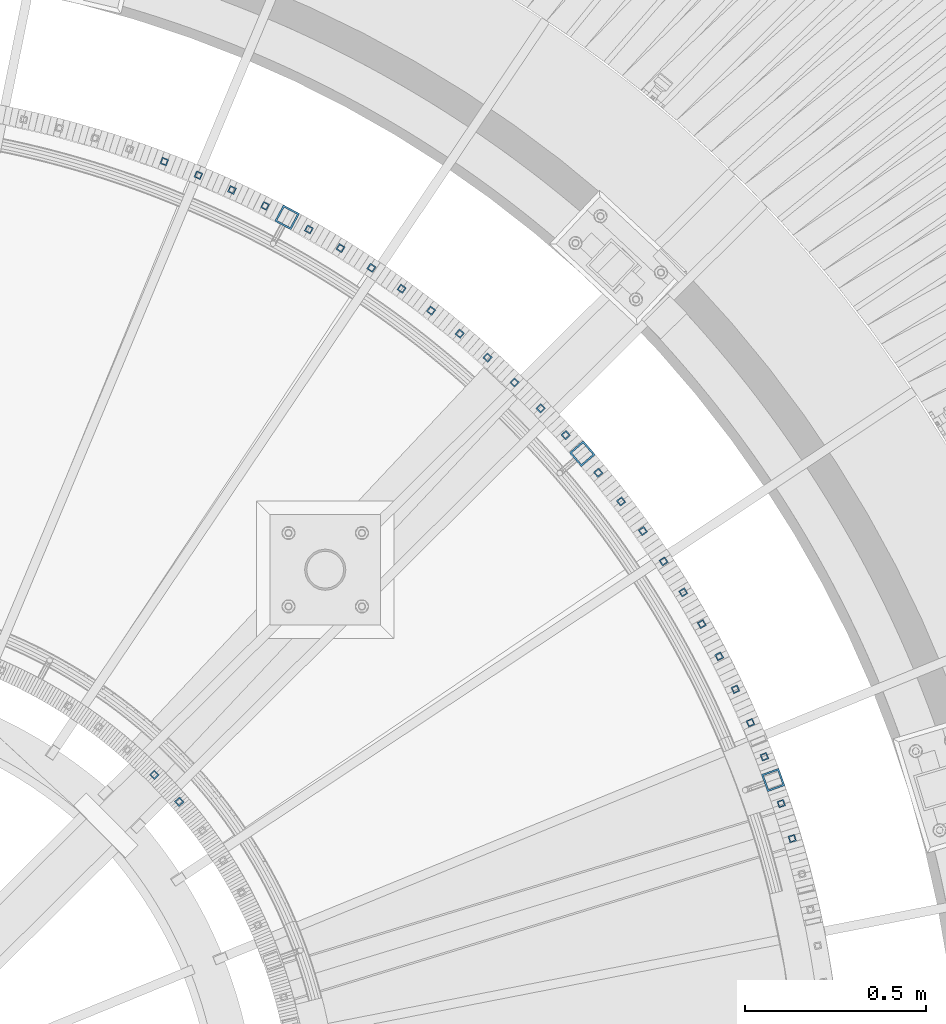
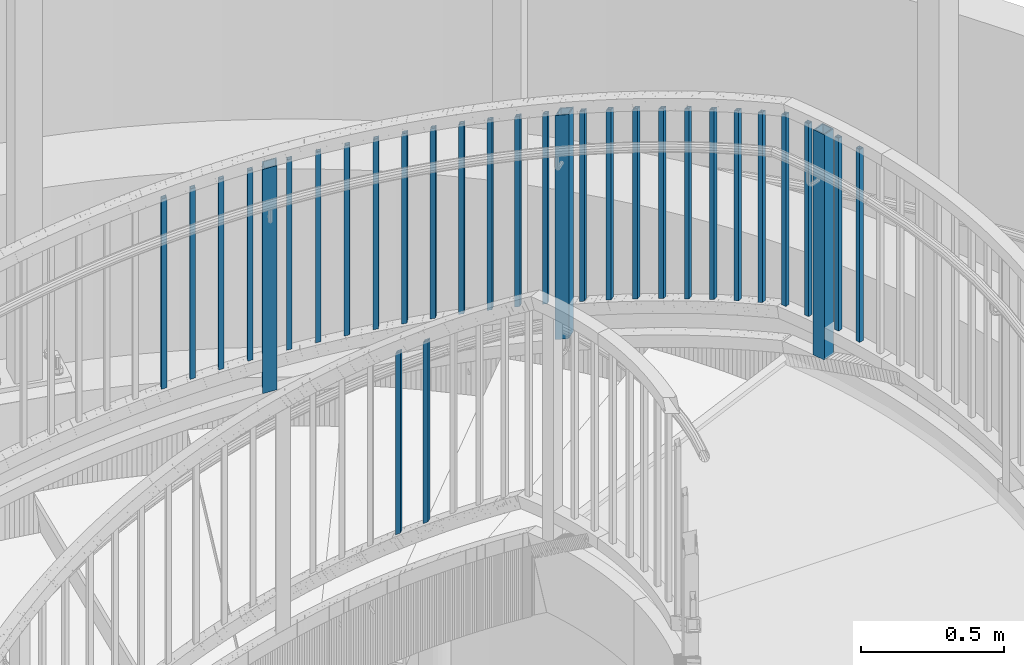
# One storey, part 267 of 975: 31 columns.
"""IFC2X3 building model written with IfcOpenShell, lengths in millimetres."""

import ifcopenshell
import ifcopenshell.guid

model = None  # the IFC model being written
_history = None  # IfcOwnerHistory: only IFC2X3 demands one
_inside = {}  # id of a spatial element -> (the spatial element, [elements in it])
_under = {}  # id of a project, library or spatial element -> (it, [spatial elements below it])
_declared = {}  # id of a project -> (the project, [libraries it declares])
_typed = {}  # id of a type object -> (the type object, [elements of that type])
_made_of = {}  # id of a material, layer set ... -> (it, [elements and type objects made of it])


def new_model(schema):
    """Start an empty IFC model of exactly this schema.

    Asked for "IFC4X3", IfcOpenShell would pick the latest addendum, in which some entities
    have other attributes; the version numbers below select the first issue.
    IFC2X3 requires an IfcOwnerHistory on every rooted entity: one is made here for all.
    """
    global model, _history
    if schema == "IFC4X3":
        model = ifcopenshell.file(schema_version=(4, 3, 0, 0))
    else:
        model = ifcopenshell.file(schema=schema)
    _inside.clear()
    _under.clear()
    _declared.clear()
    _typed.clear()
    _made_of.clear()
    _history = None
    if model.schema == "IFC2X3":
        org = make("IfcOrganization", Name="unknown")
        user = make(
            "IfcPersonAndOrganization",
            ThePerson=make("IfcPerson", FamilyName="unknown"),
            TheOrganization=org,
        )
        app = make(
            "IfcApplication",
            ApplicationDeveloper=org,
            Version="unknown",
            ApplicationFullName="unknown",
            ApplicationIdentifier="unknown",
        )
        _history = make(
            "IfcOwnerHistory",
            OwningUser=user,
            OwningApplication=app,
            ChangeAction="ADDED",
            CreationDate=0,
        )
    return model


def make(cls, **values):
    """One entity of the class cls with the attributes given. An attribute that is None is left unset."""
    return model.create_entity(
        cls, **{name: value for name, value in values.items() if value is not None}
    )


def rooted(cls, **values):
    """An entity with a GlobalId (a new one), such as an element, a storey or a relation."""
    return make(cls, GlobalId=ifcopenshell.guid.new(), OwnerHistory=_history, **values)


def si_unit(unit_type, name, prefix=None):
    """IfcSIUnit, for example si_unit("LENGTHUNIT", "METRE", prefix="MILLI")."""
    return make("IfcSIUnit", UnitType=unit_type, Prefix=prefix, Name=name)


def assignment(units):
    """IfcUnitAssignment: the units of a project."""
    return None if units is None else make("IfcUnitAssignment", Units=units)


def point(xyz):
    """IfcCartesianPoint."""
    return None if xyz is None else make("IfcCartesianPoint", Coordinates=xyz)


def direction(xyz):
    """IfcDirection."""
    return None if xyz is None else make("IfcDirection", DirectionRatios=xyz)


def frame(location, z_axis=None, x_axis=None):
    """IfcAxis2Placement3D, a coordinate frame: its origin and axes. An axis left out is left unset."""
    return make(
        "IfcAxis2Placement3D",
        Location=point(location),
        Axis=direction(z_axis),
        RefDirection=direction(x_axis),
    )


def origin_with_axes():
    """The frame at (0, 0, 0) with the z axis (0, 0, 1) and the x axis (1, 0, 0) written out."""
    return frame((0.0, 0.0, 0.0), z_axis=(0.0, 0.0, 1.0), x_axis=(1.0, 0.0, 0.0))


def place(relative_to, where):
    """IfcLocalPlacement: puts the frame where relative to a parent placement (None: the world)."""
    return make(
        "IfcLocalPlacement", PlacementRelTo=relative_to, RelativePlacement=where
    )


def context(
    kind, dimensions, precision=None, world=None, true_north=None, identifier=None
):
    """IfcGeometricRepresentationContext, for example the 3D "Model" context."""
    return make(
        "IfcGeometricRepresentationContext",
        ContextIdentifier=identifier,
        ContextType=kind,
        CoordinateSpaceDimension=dimensions,
        Precision=precision,
        WorldCoordinateSystem=world,
        TrueNorth=true_north,
    )


def subcontext(parent, identifier, kind, view, scale=None):
    """IfcGeometricRepresentationSubContext, for example "Body" below "Model"."""
    return make(
        "IfcGeometricRepresentationSubContext",
        ContextIdentifier=identifier,
        ContextType=kind,
        ParentContext=parent,
        TargetScale=scale,
        TargetView=view,
    )


def project(units=None, contexts=None):
    """IfcProject with its units and contexts."""
    return rooted(
        "IfcProject",
        Name="project",
        RepresentationContexts=contexts,
        UnitsInContext=assignment(units),
    )


def spatial(cls, under=None, at=None, **own):
    """A site, building, storey or space (cls), placed at a placement, below another one or the project."""
    s = rooted(cls, ObjectPlacement=at, **own)
    if under is not None:
        _under.setdefault(under.id(), (under, []))[1].append(s)
    return s


def faces_of(points, faces, orient=None, outer=None):
    """IfcFace entities. A face is a list of loops; a loop is a list of indices into points, from 0.

    orient and outer hold one flag for each loop. By default every Orientation is true, the
    first loop of a face is its IfcFaceOuterBound and the others are IfcFaceBound.
    """
    made = []
    for i, loops in enumerate(faces):
        bounds = []
        for j, loop in enumerate(loops):
            is_outer = j == 0 if outer is None else outer[i][j]
            bounds.append(
                make(
                    "IfcFaceOuterBound" if is_outer else "IfcFaceBound",
                    Bound=make("IfcPolyLoop", Polygon=[points[k] for k in loop]),
                    Orientation=True if orient is None else orient[i][j],
                )
            )
        made.append(make("IfcFace", Bounds=bounds))
    return made


def faceted_brep(points, faces, orient=None, outer=None, voids=None):
    """IfcFacetedBrep: a solid bounded by flat faces; with voids (closed shells), ...WithVoids."""
    shared = [point(p) for p in points]
    hull = make("IfcClosedShell", CfsFaces=faces_of(shared, faces, orient, outer))
    if voids is None:
        return make("IfcFacetedBrep", Outer=hull)
    return make(
        "IfcFacetedBrepWithVoids",
        Outer=hull,
        Voids=[
            make(cls, CfsFaces=faces_of(shared, fs, o, b)) for cls, fs, o, b in voids
        ],
    )


def shape(context_of_items, identifier, shape_type, items):
    """IfcShapeRepresentation: the items that make up one representation, for example the "Body"."""
    return make(
        "IfcShapeRepresentation",
        ContextOfItems=context_of_items,
        RepresentationIdentifier=identifier,
        RepresentationType=shape_type,
        Items=items,
    )


def material(Name=None, Category=None):
    """IfcMaterial."""
    return make("IfcMaterial", Name=Name, Category=Category)


def made_of(thing, what):
    """Note that an element or type object is made of a material, layer set ...; save() writes the relation."""
    if what is not None:
        _made_of.setdefault(what.id(), (what, []))[1].append(thing)
    return thing


def type_object(cls, material=None, **own):
    """A type object (cls), such as IfcWallType, which elements share."""
    return made_of(rooted(cls, **own), material)


def element(
    cls,
    number,
    at=None,
    inside=None,
    cuts=None,
    type_object=None,
    material=None,
    context=None,
    identifier="Body",
    shape_type=None,
    held_by="IfcProductDefinitionShape",
    body=None,
    shapes=None,
    **own,
):
    """One element of the class cls, such as IfcWall. Its Tag is "e" and its number.

    at: its placement. inside: the storey or other place that contains it. cuts: it is an
    opening in that element (IfcRelVoidsElement). A single representation is given by context,
    identifier, shape_type and body (its items); several are given by shapes. held_by: the class
    of the entity that holds the representations. save() writes the other relations.
    """
    e = rooted(cls, Tag="e%d" % number, ObjectPlacement=at, **own)
    if body is not None:
        shapes = [shape(context, identifier, shape_type, body)]
    if shapes is not None:
        e.Representation = make(held_by, Representations=shapes)
    if inside is not None:
        _inside.setdefault(inside.id(), (inside, []))[1].append(e)
    if cuts is not None:
        rooted(
            "IfcRelVoidsElement", RelatingBuildingElement=cuts, RelatedOpeningElement=e
        )
    if type_object is not None:
        _typed.setdefault(type_object.id(), (type_object, []))[1].append(e)
    return made_of(e, material)


def aggregate(whole, parts):
    """IfcRelAggregates: a whole, such as a stair, and the parts it consists of."""
    return rooted("IfcRelAggregates", RelatingObject=whole, RelatedObjects=parts)


def save(model, path):
    """Write the relations noted so far, then the file.

    IfcRelAggregates (storeys below a building ...), IfcRelContainedInSpatialStructure (elements
    in a storey), IfcRelDefinesByType, IfcRelAssociatesMaterial and IfcRelDeclares: one each for
    every whole, place, type object, material and project.
    """
    for whole, parts in _under.values():
        aggregate(whole, parts)
    for where, things in _inside.values():
        rooted(
            "IfcRelContainedInSpatialStructure",
            RelatedElements=things,
            RelatingStructure=where,
        )
    for kind, things in _typed.values():
        rooted("IfcRelDefinesByType", RelatedObjects=things, RelatingType=kind)
    for what, things in _made_of.values():
        rooted("IfcRelAssociatesMaterial", RelatedObjects=things, RelatingMaterial=what)
    for by, libraries in _declared.values():
        rooted("IfcRelDeclares", RelatingContext=by, RelatedDefinitions=libraries)
    model.write(path)


model = new_model("IFC2X3")

# Units and contexts
model_context = context("Model", 3, precision=1e-05, world=origin_with_axes())
body_context = subcontext(model_context, "Body", "Model", "MODEL_VIEW")
ifc_project = project(units=[si_unit("LENGTHUNIT", "METRE", prefix="MILLI"), si_unit("AREAUNIT", "SQUARE_METRE"), si_unit("VOLUMEUNIT", "CUBIC_METRE"), si_unit("MASSUNIT", "GRAM", prefix="KILO"), si_unit("TIMEUNIT", "SECOND"), si_unit("PLANEANGLEUNIT", "RADIAN"), si_unit("SOLIDANGLEUNIT", "STERADIAN"), si_unit("THERMODYNAMICTEMPERATUREUNIT", "DEGREE_CELSIUS"), si_unit("LUMINOUSINTENSITYUNIT", "LUMEN")], contexts=[model_context])

# Site, building, storey
site_placement = place(None, origin_with_axes())
site = spatial("IfcSite", under=ifc_project, at=site_placement, CompositionType="ELEMENT")
building_placement = place(site_placement, origin_with_axes())
building = spatial("IfcBuilding", under=site, at=building_placement, Name="Undefined", CompositionType="ELEMENT")
storey_placement = place(building_placement, origin_with_axes())
storey = spatial("IfcBuildingStorey", under=building, at=storey_placement, Name="Undefined", CompositionType="ELEMENT", Elevation=0.0)

# Columns
ifc_material = material()
column_type_1 = type_object("IfcColumnType", Name="HSS3/4X3/4X.120_TUBES", PredefinedType="NOTDEFINED")
for number, where, z_axis, x_axis, name in (
    (1, (35791.5286302242, 4316.64671704083, 2003.8139443435), (0.756766922064852, 0.653684806056015, 0.0), (0.0, 0.0, 1.0), "PICKET"),
    (2, (35722.3889491887, 4391.04076110086, 1935.35300734351), (0.707267199985595, 0.706946325985599, 0.0), (0.0, 0.0, 1.0), "PICKET"),
):
    element("IfcColumn", number, at=place(storey_placement, frame(where, z_axis=z_axis, x_axis=x_axis)), inside=storey, type_object=column_type_1, material=ifc_material, Name=name, ObjectType="HSS3/4X3/4X.120_TUBES", context=body_context, shape_type="Brep", body=[
        faceted_brep([(81.3030822565961, 6.34999999999491, -6.34999999997672), (73.0243810963957, -6.34999999999854, -6.35000000000582), (849.31820965341, -6.34999999999854, -6.35000000000582), (857.556470281766, 6.34999999999491, -6.34999999997672), (73.0243810963952, -6.34999999999127, 6.34999999998399), (849.318209653409, -6.34999999999127, 6.34999999998399), (81.3030822565956, 6.35000000000218, 6.34999999999854), (857.556470281765, 6.35000000000218, 6.34999999999854), (83.3727575466464, 9.52499999999054, -9.52499999997235), (83.3727575466455, 9.52500000000509, 9.52500000000146), (859.616035438854, 9.52500000000509, 9.52500000000146), (859.616035438854, 9.52499999999054, -9.52499999997235), (70.9547058063449, -9.5249999999869, 9.52499999997235), (847.25864449632, -9.5249999999869, 9.52499999997235), (70.9547058063458, -9.52500000000146, -9.52499999999418), (847.258644496321, -9.52500000000146, -9.52499999999418)], [[[0, 1, 2, 3]], [[1, 4, 5, 2]], [[4, 6, 7, 5]], [[6, 0, 3, 7]], [[8, 9, 10, 11]], [[9, 12, 13, 10]], [[12, 14, 15, 13]], [[14, 8, 11, 15]], [[13, 15, 11, 10], [5, 7, 3, 2]], [[14, 12, 9, 8], [6, 4, 1, 0]]]),
    ])
column_1_placement = place(storey_placement, frame((37410.4596622562, 4441.21397734176, 2285.99999999872), z_axis=(0.932284067912367, 0.361726991965997, 0.0), x_axis=(0.0, 0.0, 1.0)))
element("IfcColumn", 3, at=column_1_placement, inside=storey, type_object=column_type_1, material=ifc_material, Name="PICKET", ObjectType="HSS3/4X3/4X.120_TUBES", context=body_context, shape_type="Brep", body=[
    faceted_brep([(38.1000007642197, 6.35000000000764, -6.35000000002765), (38.1000007642197, -6.35000000000036, -6.34999999999127), (863.600000001279, -6.35000000000036, -6.34999999999127), (863.600000001279, 6.35000000000764, -6.35000000002765), (38.1000007642197, -6.35000000000582, 6.35000000002765), (863.600000001279, -6.35000000000582, 6.35000000002765), (38.1000007642197, 6.35000000000036, 6.34999999999127), (863.600000001279, 6.35000000000036, 6.34999999999127), (38.1000007642197, 9.52500000001055, -9.52500000003783), (38.1000007642197, 9.52499999999964, 9.5249999999869), (863.600000001279, 9.52499999999964, 9.5249999999869), (863.600000001279, 9.52500000001055, -9.52500000003783), (38.1000007642197, -9.52500000001055, 9.52500000003783), (863.600000001279, -9.52500000001055, 9.52500000003783), (38.1000007642197, -9.52499999999964, -9.5249999999869), (863.600000001279, -9.52499999999964, -9.5249999999869)], [[[0, 1, 2, 3]], [[1, 4, 5, 2]], [[4, 6, 7, 5]], [[6, 0, 3, 7]], [[8, 9, 10, 11]], [[9, 12, 13, 10]], [[12, 14, 15, 13]], [[14, 8, 11, 15]], [[13, 15, 11, 10], [5, 7, 3, 2]], [[14, 12, 9, 8], [6, 4, 1, 0]]]),
])
for number, where, z_axis, x_axis, name in (
    (4, (36860.8759692985, 5331.27427673515, 1980.9953441068), (0.740730798253926, 0.671801968230297, 0.0), (0.0, 0.0, 1.0), "PICKET"),
    (5, (36028.8263063679, 5965.26396950194, 1646.6384123963), (0.450779479086537, 0.892635346171364, 0.0), (0.0, 0.0, 1.0), "PICKET"),
):
    element("IfcColumn", number, at=place(storey_placement, frame(where, z_axis=z_axis, x_axis=x_axis)), inside=storey, type_object=column_type_1, material=ifc_material, Name=name, ObjectType="HSS3/4X3/4X.120_TUBES", context=body_context, shape_type="Brep", body=[
        faceted_brep([(48.9778304891588, 6.35000000000036, -6.34999999999854), (44.9444858438005, -6.35000000000582, -6.34999999999127), (858.946568247068, -6.35000000000582, -6.34999999999127), (863.063419332087, 6.35000000000036, -6.34999999999854), (44.9444858438051, -6.35000000000036, 6.35000000000582), (858.946568247072, -6.35000000000036, 6.35000000000582), (48.9778304891634, 6.350000000004, 6.34999999999854), (863.063419332091, 6.350000000004, 6.34999999999854), (49.9861666504976, 9.52499999999964, -9.52500000000146), (49.9861666505039, 9.52500000000691, 9.52499999999418), (864.092632103347, 9.52500000000691, 9.52499999999418), (864.09263210334, 9.52499999999964, -9.52500000000146), (43.9361496824667, -9.52500000000146, 9.52500000001601), (857.917355475819, -9.52500000000146, 9.52500000001601), (43.9361496824599, -9.52500000000691, -9.52499999997963), (857.917355475812, -9.52500000000691, -9.52499999997963)], [[[0, 1, 2, 3]], [[1, 4, 5, 2]], [[4, 6, 7, 5]], [[6, 0, 3, 7]], [[8, 9, 10, 11]], [[9, 12, 13, 10]], [[12, 14, 15, 13]], [[14, 8, 11, 15]], [[13, 15, 11, 10], [5, 7, 3, 2]], [[14, 12, 9, 8], [6, 4, 1, 0]]]),
    ])
column_2_placement = place(storey_placement, frame((37372.0646915228, 4535.26045184344, 2282.60996286), z_axis=(0.918899380903795, 0.394491986958698, 0.0), x_axis=(0.0, 0.0, 1.0)))
element("IfcColumn", 6, at=column_2_placement, inside=storey, type_object=column_type_1, material=ifc_material, Name="PICKET", ObjectType="HSS3/4X3/4X.120_TUBES", context=body_context, shape_type="Brep", body=[
    faceted_brep([(41.4900379029436, 6.35000000001492, -6.34999999996944), (41.4900379029436, -6.34999999999309, -6.34999999998399), (858.946568247068, -6.35000000000582, -6.34999999999127), (863.063419332087, 6.35000000000036, -6.34999999999854), (41.4900379029436, -6.35000000001673, 6.34999999997672), (858.946568247072, -6.35000000000036, 6.35000000000582), (41.4900379029436, 6.34999999999309, 6.34999999999127), (863.063419332091, 6.350000000004, 6.34999999999854), (41.4900379029436, 9.52500000002874, -9.52499999995052), (41.4900379029436, 9.52499999999054, 9.52499999999418), (864.092632103347, 9.52500000000691, 9.52499999999418), (864.09263210334, 9.52499999999964, -9.52500000000146), (41.4900379029436, -9.52500000002692, 9.5249999999578), (857.917355475819, -9.52500000000146, 9.52500000001601), (41.4900379029436, -9.52499999999236, -9.5249999999869), (857.917355475812, -9.52500000000691, -9.52499999997963)], [[[0, 1, 2, 3]], [[1, 4, 5, 2]], [[4, 6, 7, 5]], [[6, 0, 3, 7]], [[8, 9, 10, 11]], [[9, 12, 13, 10]], [[12, 14, 15, 13]], [[14, 8, 11, 15]], [[13, 15, 11, 10], [5, 7, 3, 2]], [[14, 12, 9, 8], [6, 4, 1, 0]]]),
])
for number, where, z_axis, x_axis, name in (
    (7, (36791.3277996833, 5405.31483544643, 1948.6500321068), (0.716493190936824, 0.697594084938489, 0.0), (0.0, 0.0, 1.0), "PICKET"),
    (8, (35937.3637333079, 6009.46295094215, 1614.2931003963), (0.418908657004417, 0.908028379009575, 0.0), (0.0, 0.0, 1.0), "PICKET"),
    (9, (37330.3655053388, 4627.88965453001, 2249.39365303497), (0.904363592397859, 0.426762806187746, 0.0), (0.0, 0.0, 1.0), "PICKET"),
    (10, (36719.2030524597, 5476.84785627615, 1916.3047201068), (0.691358036695283, 0.722512328681556, 0.0), (0.0, 0.0, 1.0), "PICKET"),
    (11, (35844.3943390343, 6050.39758126304, 1581.9477883963), (0.386513068140884, 0.922283930336163, 0.0), (0.0, 0.0, 1.0), "PICKET"),
    (12, (37285.4145676937, 4718.98501904394, 2217.24677803497), (0.888694912711158, 0.45849902085098, 0.0), (0.0, 0.0, 1.0), "PICKET"),
    (13, (36644.5920779276, 5545.78373017694, 1883.9594081068), (0.665356821888081, 0.746525484874423, 0.0), (0.0, 0.0, 1.0), "PICKET"),
    (14, (35750.0345858293, 6088.0165818637, 1549.6024763963), (0.353633297003289, 0.9353841410087, 0.0), (0.0, 0.0, 1.0), "PICKET"),
    (15, (37237.2681124864, 4808.4326075082, 2185.09990303497), (0.871912969010984, 0.48966087700617, 0.0), (0.0, 0.0, 1.0), "PICKET"),
    (16, (36567.5883408711, 5612.03610153403, 1851.6140961068), (0.638522118226785, 0.769603472273339, 0.0), (0.0, 0.0, 1.0), "PICKET"),
    (17, (37185.9864525339, 4896.12036938869, 2152.95302803497), (0.854038785193937, 0.52020933611813, 0.0), (0.0, 0.0, 1.0), "PICKET"),
    (18, (36488.2883034758, 5675.5219763425, 1819.2687841068), (0.610887540783144, 0.791717381718958, 0.0), (0.0, 0.0, 1.0), "PICKET"),
    (19, (37131.6338281077, 4981.93845867696, 2120.80615303497), (0.835094750702721, 0.550106132804172, 0.0), (0.0, 0.0, 1.0), "PICKET"),
    (20, (36406.7913044907, 5736.16182617341, 1786.9234721068), (0.582487707160523, 0.812839511224004, 0.0), (0.0, 0.0, 1.0), "PICKET"),
    (21, (37074.2783264612, 5065.77937149387, 2088.65927803497), (0.815104598157582, 0.579313813112001, 0.0), (0.0, 0.0, 1.0), "PICKET"),
    (22, (36323.1994347873, 5793.87968779869, 1754.5781601068), (0.553358195116976, 0.832943400176076, 0.0), (0.0, 0.0, 1.0), "PICKET"),
    (23, (37013.9917965362, 5147.53808075901, 2056.51240303497), (0.794093367368972, 0.607795791282407, 0.0), (0.0, 0.0, 1.0), "PICKET"),
    (24, (36237.6174094711, 5848.60325834987, 1722.2328481068), (0.523535494143253, 0.852003865233122, 0.0), (0.0, 0.0, 1.0), "PICKET"),
):
    element("IfcColumn", number, at=place(storey_placement, frame(where, z_axis=z_axis, x_axis=x_axis)), inside=storey, type_object=column_type_1, material=ifc_material, Name=name, ObjectType="HSS3/4X3/4X.120_TUBES", context=body_context, shape_type="Brep", body=[
        faceted_brep([(48.9778304891588, 6.35000000000036, -6.34999999999854), (44.9444858438005, -6.35000000000582, -6.34999999999127), (858.946568247068, -6.35000000000582, -6.34999999999127), (863.063419332087, 6.35000000000036, -6.34999999999854), (44.9444858438051, -6.35000000000036, 6.35000000000582), (858.946568247072, -6.35000000000036, 6.35000000000582), (48.9778304891634, 6.350000000004, 6.34999999999854), (863.063419332091, 6.350000000004, 6.34999999999854), (49.9861666504976, 9.52499999999964, -9.52500000000146), (49.9861666505039, 9.52500000000691, 9.52499999999418), (864.092632103347, 9.52500000000691, 9.52499999999418), (864.09263210334, 9.52499999999964, -9.52500000000146), (43.9361496824667, -9.52500000000146, 9.52500000001601), (857.917355475819, -9.52500000000146, 9.52500000001601), (43.9361496824599, -9.52500000000691, -9.52499999997963), (857.917355475812, -9.52500000000691, -9.52499999997963)], [[[0, 1, 2, 3]], [[1, 4, 5, 2]], [[4, 6, 7, 5]], [[6, 0, 3, 7]], [[8, 9, 10, 11]], [[9, 12, 13, 10]], [[12, 14, 15, 13]], [[14, 8, 11, 15]], [[13, 15, 11, 10], [5, 7, 3, 2]], [[14, 12, 9, 8], [6, 4, 1, 0]]]),
    ])
column_3_placement = place(storey_placement, frame((37487.5604377426, 4214.80965608953, 2285.99999999872), z_axis=(0.959164555840003, 0.282848642952817, 0.0), x_axis=(0.0, 0.0, 1.0)))
element("IfcColumn", 25, at=column_3_placement, inside=storey, type_object=column_type_1, material=ifc_material, Name="PICKET", ObjectType="HSS3/4X3/4X.120_TUBES", context=body_context, shape_type="Brep", body=[
    faceted_brep([(38.1000007642197, 6.35000000000764, -6.35000000002765), (38.1000007642197, -6.35000000000036, -6.34999999999127), (863.600000001279, -6.35000000000036, -6.34999999999127), (863.600000001279, 6.35000000000764, -6.35000000002765), (38.1000007642197, -6.35000000000582, 6.35000000002765), (863.600000001279, -6.35000000000582, 6.35000000002765), (38.1000007642197, 6.35000000000036, 6.34999999999127), (863.600000001279, 6.35000000000036, 6.34999999999127), (38.1000007642197, 9.52500000001055, -9.52500000003783), (38.1000007642197, 9.52499999999964, 9.5249999999869), (863.600000001279, 9.52499999999964, 9.5249999999869), (863.600000001279, 9.52500000001055, -9.52500000003783), (38.1000007642197, -9.52500000001055, 9.52500000003783), (863.600000001279, -9.52500000001055, 9.52500000003783), (38.1000007642197, -9.52499999999964, -9.5249999999869), (863.600000001279, -9.52499999999964, -9.5249999999869)], [[[0, 1, 2, 3]], [[1, 4, 5, 2]], [[4, 6, 7, 5]], [[6, 0, 3, 7]], [[8, 9, 10, 11]], [[9, 12, 13, 10]], [[12, 14, 15, 13]], [[14, 8, 11, 15]], [[13, 15, 11, 10], [5, 7, 3, 2]], [[14, 12, 9, 8], [6, 4, 1, 0]]]),
])
column_4_placement = place(storey_placement, frame((36950.8497589588, 5227.11216775771, 2024.36552803497), z_axis=(0.772087379806669, 0.635516386840869, 0.0), x_axis=(0.0, 0.0, 1.0)))
element("IfcColumn", 26, at=column_4_placement, inside=storey, type_object=column_type_1, material=ifc_material, Name="PICKET", ObjectType="HSS3/4X3/4X.120_TUBES", context=body_context, shape_type="Brep", body=[
    faceted_brep([(48.9778304891588, 6.35000000000036, -6.34999999999854), (44.9444858438005, -6.35000000000582, -6.34999999999127), (858.946568247068, -6.35000000000582, -6.34999999999127), (863.063419332087, 6.35000000000036, -6.34999999999854), (44.9444858438051, -6.35000000000036, 6.35000000000582), (858.946568247072, -6.35000000000036, 6.35000000000582), (48.9778304891634, 6.350000000004, 6.34999999999854), (863.063419332091, 6.350000000004, 6.34999999999854), (49.9861666504976, 9.52499999999964, -9.52500000000146), (49.9861666505039, 9.52500000000691, 9.52499999999418), (864.092632103347, 9.52500000000691, 9.52499999999418), (864.09263210334, 9.52499999999964, -9.52500000000146), (43.9361496824667, -9.52500000000146, 9.52500000001601), (857.917355475819, -9.52500000000146, 9.52500000001601), (43.9361496824599, -9.52500000000691, -9.52499999997963), (857.917355475812, -9.52500000000691, -9.52499999997963)], [[[0, 1, 2, 3]], [[1, 4, 5, 2]], [[4, 6, 7, 5]], [[6, 0, 3, 7]], [[8, 9, 10, 11]], [[9, 12, 13, 10]], [[12, 14, 15, 13]], [[14, 8, 11, 15]], [[13, 15, 11, 10], [5, 7, 3, 2]], [[14, 12, 9, 8], [6, 4, 1, 0]]]),
])
column_5_placement = place(storey_placement, frame((37457.1290697658, 4311.72654870461, 2285.99999999872), z_axis=(0.948554369899527, 0.316614287966465, 0.0), x_axis=(0.0, 0.0, 1.0)))
element("IfcColumn", 27, at=column_5_placement, inside=storey, type_object=column_type_1, material=ifc_material, Name="PICKET", ObjectType="HSS3/4X3/4X.120_TUBES", context=body_context, shape_type="Brep", body=[
    faceted_brep([(38.1000007642197, 6.35000000000764, -6.35000000002765), (38.1000007642197, -6.35000000000036, -6.34999999999127), (863.600000001279, -6.35000000000036, -6.34999999999127), (863.600000001279, 6.35000000000764, -6.35000000002765), (38.1000007642197, -6.35000000000582, 6.35000000002765), (863.600000001279, -6.35000000000582, 6.35000000002765), (38.1000007642197, 6.35000000000036, 6.34999999999127), (863.600000001279, 6.35000000000036, 6.34999999999127), (38.1000007642197, 9.52500000001055, -9.52500000003783), (38.1000007642197, 9.52499999999964, 9.5249999999869), (863.600000001279, 9.52499999999964, 9.5249999999869), (863.600000001279, 9.52500000001055, -9.52500000003783), (38.1000007642197, -9.52500000001055, 9.52500000003783), (863.600000001279, -9.52500000001055, 9.52500000003783), (38.1000007642197, -9.52499999999964, -9.5249999999869), (863.600000001279, -9.52499999999964, -9.5249999999869)], [[[0, 1, 2, 3]], [[1, 4, 5, 2]], [[4, 6, 7, 5]], [[6, 0, 3, 7]], [[8, 9, 10, 11]], [[9, 12, 13, 10]], [[12, 14, 15, 13]], [[14, 8, 11, 15]], [[13, 15, 11, 10], [5, 7, 3, 2]], [[14, 12, 9, 8], [6, 4, 1, 0]]]),
])
column_6_placement = place(storey_placement, frame((36150.152436705, 5900.26398589151, 1689.8875361068), z_axis=(0.493056962003581, 0.869997030006309, 0.0), x_axis=(0.0, 0.0, 1.0)))
element("IfcColumn", 28, at=column_6_placement, inside=storey, type_object=column_type_1, material=ifc_material, Name="PICKET", ObjectType="HSS3/4X3/4X.120_TUBES", context=body_context, shape_type="Brep", body=[
    faceted_brep([(48.9778304891588, 6.35000000000036, -6.34999999999854), (44.9444858438005, -6.35000000000582, -6.34999999999127), (858.946568247068, -6.35000000000582, -6.34999999999127), (863.063419332087, 6.35000000000036, -6.34999999999854), (44.9444858438051, -6.35000000000036, 6.35000000000582), (858.946568247072, -6.35000000000036, 6.35000000000582), (48.9778304891634, 6.350000000004, 6.34999999999854), (863.063419332091, 6.350000000004, 6.34999999999854), (49.9861666504976, 9.52499999999964, -9.52500000000146), (49.9861666505039, 9.52500000000691, 9.52499999999418), (864.092632103347, 9.52500000000691, 9.52499999999418), (864.09263210334, 9.52499999999964, -9.52500000000146), (43.9361496824667, -9.52500000000146, 9.52500000001601), (857.917355475819, -9.52500000000146, 9.52500000001601), (43.9361496824599, -9.52500000000691, -9.52499999997963), (857.917355475812, -9.52500000000691, -9.52499999997963)], [[[0, 1, 2, 3]], [[1, 4, 5, 2]], [[4, 6, 7, 5]], [[6, 0, 3, 7]], [[8, 9, 10, 11]], [[9, 12, 13, 10]], [[12, 14, 15, 13]], [[14, 8, 11, 15]], [[13, 15, 11, 10], [5, 7, 3, 2]], [[14, 12, 9, 8], [6, 4, 1, 0]]]),
])
column_type_2 = type_object("IfcColumnType", Name="HSS2X2X.188_TUBES", PredefinedType="NOTDEFINED")
column_7_placement = place(storey_placement, frame((37434.6764463778, 4376.78816188138, 2133.6), z_axis=(0.940762469801482, 0.339066328928449, 0.0), x_axis=(0.0, 0.0, 1.0)))
element("IfcColumn", 29, at=column_7_placement, inside=storey, type_object=column_type_2, material=ifc_material, Name="HANDRAIL", ObjectType="HSS2X2X.188_TUBES", context=body_context, shape_type="Brep", body=[
    faceted_brep([(50.7999992370605, 20.6375000000016, -20.637500000099), (50.7999992370605, -20.6374999999998, -20.6375000000262), (1016.0, -20.6374999999935, -20.6374999999898), (1016.0, 20.6374999999716, -20.6375000000371), (50.7999992370605, -20.6375000000025, 20.6375000001208), (1016.0, -20.6374999999716, 20.6375000000226), (50.7999992370605, 20.637499999998, 20.6375000000407), (1016.0, 20.6374999999898, 20.6374999999789), (50.7999999999411, 25.3999999999996, -25.4000000000487), (50.8000000000102, 25.3999999999996, 25.4000000000015), (1016.00000000002, 25.4000000000087, 25.3999999999724), (1016.0, 25.3999999999651, -25.4000000000415), (50.7999992370605, -25.4000000000024, 25.400000000147), (1016.00000000003, -25.4000000000087, 25.4000000000124), (50.7999999999411, -25.3999999999996, -25.4000000000487), (1016.0, -25.3999999999869, -25.3999999999833)], [[[0, 1, 2, 3]], [[1, 4, 5, 2]], [[4, 6, 7, 5]], [[6, 0, 3, 7]], [[8, 9, 10, 11]], [[9, 12, 13, 10]], [[12, 14, 15, 13]], [[14, 8, 11, 15]], [[13, 15, 11, 10], [5, 7, 3, 2]], [[14, 12, 9, 8], [6, 4, 1, 0]]]),
])
for number, where, z_axis, x_axis, name in (
    (30, (36906.5724215876, 5279.80612816893, 1850.07536187521), (0.756766922064852, 0.653684806056015, 0.0), (0.0, 0.0, 1.0), "HANDRAIL"),
    (31, (36089.9321546522, 5933.59045732091, 1515.54481906435), (0.472243102909618, 0.881468349831289, 0.0), (0.0, 0.0, 1.0), "HANDRAIL"),
):
    element("IfcColumn", number, at=place(storey_placement, frame(where, z_axis=z_axis, x_axis=x_axis)), inside=storey, type_object=column_type_2, material=ifc_material, Name=name, ObjectType="HSS2X2X.188_TUBES", context=body_context, shape_type="Brep", body=[
        faceted_brep([(59.7770034089217, 20.6374999999425, -20.6375000000444), (46.6339334019876, -20.6375000000517, -20.6375000000335), (1006.79125658838, -20.6375000000517, -20.6375000000335), (1019.96851403156, 20.6374999999425, -20.6375000000444), (46.6339334020035, -20.6374999999389, 20.637500000048), (1006.7912565884, -20.6374999999389, 20.637500000048), (59.7770034089381, 20.6375000000517, 20.6375000000335), (1019.96851403158, 20.6375000000517, 20.6375000000335), (61.2935114866432, 25.3999999999287, -25.4000000000524), (61.2935114866632, 25.4000000000633, 25.4000000000415), (1021.48896681348, 25.4000000000633, 25.4000000000415), (1021.48896681346, 25.3999999999287, -25.4000000000524), (45.1174253242825, -25.3999999999251, 25.400000000056), (1005.27080380649, -25.3999999999251, 25.400000000056), (45.1174253242625, -25.4000000000597, -25.4000000000415), (1005.27080380647, -25.4000000000597, -25.4000000000415)], [[[0, 1, 2, 3]], [[1, 4, 5, 2]], [[4, 6, 7, 5]], [[6, 0, 3, 7]], [[8, 9, 10, 11]], [[9, 12, 13, 10]], [[12, 14, 15, 13]], [[14, 8, 11, 15]], [[13, 15, 11, 10], [5, 7, 3, 2]], [[14, 12, 9, 8], [6, 4, 1, 0]]]),
    ])

save(model, "model.ifc")
